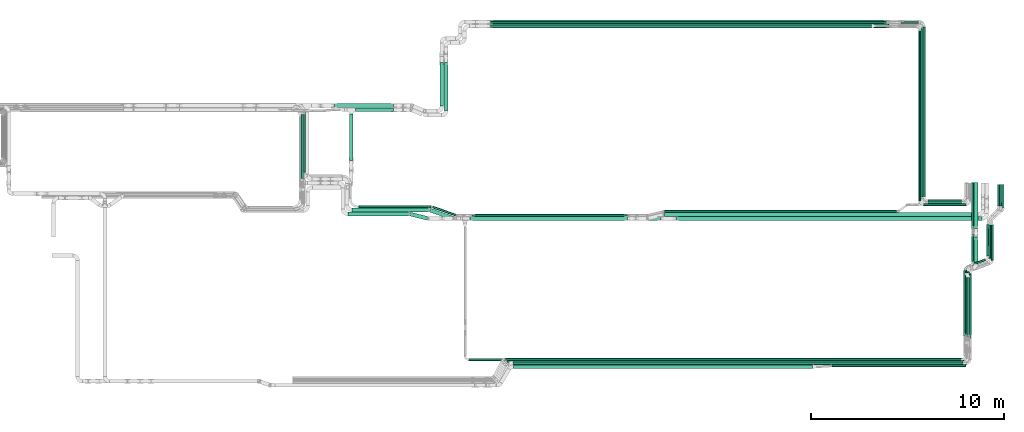
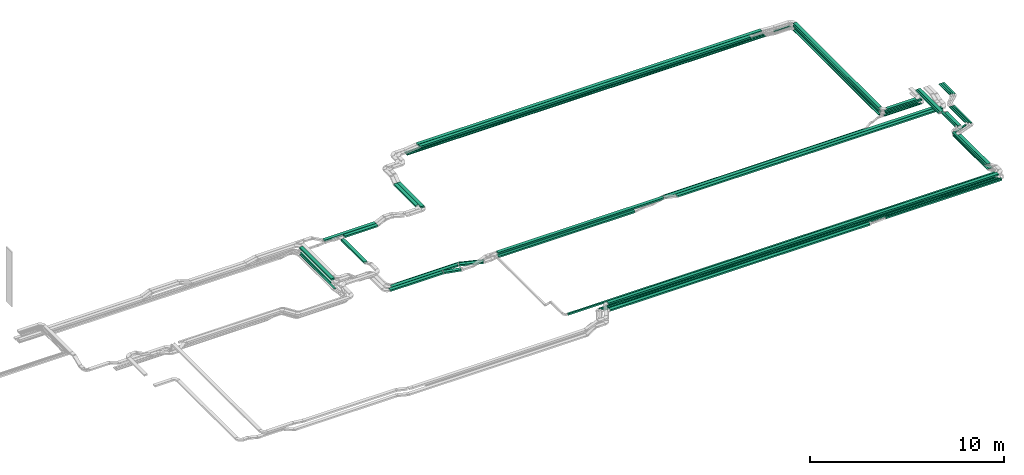
# One storey, part 2 of 25: 59 flow segments.
"""IFC2X3 building model written with IfcOpenShell, lengths in millimetres."""

import ifcopenshell
import ifcopenshell.guid

model = None  # the IFC model being written
_history = None  # IfcOwnerHistory: only IFC2X3 demands one
_inside = {}  # id of a spatial element -> (the spatial element, [elements in it])
_under = {}  # id of a project, library or spatial element -> (it, [spatial elements below it])
_declared = {}  # id of a project -> (the project, [libraries it declares])
_typed = {}  # id of a type object -> (the type object, [elements of that type])
_made_of = {}  # id of a material, layer set ... -> (it, [elements and type objects made of it])


def new_model(schema):
    """Start an empty IFC model of exactly this schema.

    Asked for "IFC4X3", IfcOpenShell would pick the latest addendum, in which some entities
    have other attributes; the version numbers below select the first issue.
    IFC2X3 requires an IfcOwnerHistory on every rooted entity: one is made here for all.
    """
    global model, _history
    if schema == "IFC4X3":
        model = ifcopenshell.file(schema_version=(4, 3, 0, 0))
    else:
        model = ifcopenshell.file(schema=schema)
    _inside.clear()
    _under.clear()
    _declared.clear()
    _typed.clear()
    _made_of.clear()
    _history = None
    if model.schema == "IFC2X3":
        org = make("IfcOrganization", Name="unknown")
        user = make(
            "IfcPersonAndOrganization",
            ThePerson=make("IfcPerson", FamilyName="unknown"),
            TheOrganization=org,
        )
        app = make(
            "IfcApplication",
            ApplicationDeveloper=org,
            Version="unknown",
            ApplicationFullName="unknown",
            ApplicationIdentifier="unknown",
        )
        _history = make(
            "IfcOwnerHistory",
            OwningUser=user,
            OwningApplication=app,
            ChangeAction="ADDED",
            CreationDate=0,
        )
    return model


def make(cls, **values):
    """One entity of the class cls with the attributes given. An attribute that is None is left unset."""
    return model.create_entity(
        cls, **{name: value for name, value in values.items() if value is not None}
    )


def entity(cls, *values):
    """Any entity or typed value of the class cls, its attributes in the order of the schema. None: left unset."""
    e = model.create_entity(cls)
    for i, value in enumerate(values):
        if value is not None:
            e[i] = value
    return e


def rooted(cls, **values):
    """An entity with a GlobalId (a new one), such as an element, a storey or a relation."""
    return make(cls, GlobalId=ifcopenshell.guid.new(), OwnerHistory=_history, **values)


def si_unit(unit_type, name, prefix=None):
    """IfcSIUnit, for example si_unit("LENGTHUNIT", "METRE", prefix="MILLI")."""
    return make("IfcSIUnit", UnitType=unit_type, Prefix=prefix, Name=name)


def converted_unit(unit_type, name, factor, base, dimensions=None, offset=None):
    """IfcConversionBasedUnit, such as the inch: factor (a typed value) times the base unit."""
    return make(
        "IfcConversionBasedUnit"
        if offset is None
        else "IfcConversionBasedUnitWithOffset",
        ConversionOffset=offset,
        Dimensions=None
        if dimensions is None
        else entity("IfcDimensionalExponents", *dimensions),
        UnitType=unit_type,
        Name=name,
        ConversionFactor=make(
            "IfcMeasureWithUnit", ValueComponent=factor, UnitComponent=base
        ),
    )


def derived_unit(unit_type, elements):
    """IfcDerivedUnit: a product of units, each with its exponent."""
    return make(
        "IfcDerivedUnit",
        Elements=[
            make("IfcDerivedUnitElement", Unit=unit, Exponent=power)
            for unit, power in elements
        ],
        UnitType=unit_type,
    )


def assignment(units):
    """IfcUnitAssignment: the units of a project."""
    return None if units is None else make("IfcUnitAssignment", Units=units)


def point(xyz):
    """IfcCartesianPoint."""
    return None if xyz is None else make("IfcCartesianPoint", Coordinates=xyz)


def direction(xyz):
    """IfcDirection."""
    return None if xyz is None else make("IfcDirection", DirectionRatios=xyz)


def frame(location, z_axis=None, x_axis=None):
    """IfcAxis2Placement3D, a coordinate frame: its origin and axes. An axis left out is left unset."""
    return make(
        "IfcAxis2Placement3D",
        Location=point(location),
        Axis=direction(z_axis),
        RefDirection=direction(x_axis),
    )


def frame_2d(location, x_axis=None):
    """IfcAxis2Placement2D, a coordinate frame in the plane: its origin and x axis."""
    return make(
        "IfcAxis2Placement2D", Location=point(location), RefDirection=direction(x_axis)
    )


def origin():
    """The frame at (0, 0, 0) with its axes left unset."""
    return frame((0.0, 0.0, 0.0))


def origin_2d_with_axis():
    """The frame at (0, 0) in the plane with the x axis (1, 0) written out."""
    return frame_2d((0.0, 0.0), x_axis=(1.0, 0.0))


def place(relative_to, where):
    """IfcLocalPlacement: puts the frame where relative to a parent placement (None: the world)."""
    return make(
        "IfcLocalPlacement", PlacementRelTo=relative_to, RelativePlacement=where
    )


def context(
    kind, dimensions, precision=None, world=None, true_north=None, identifier=None
):
    """IfcGeometricRepresentationContext, for example the 3D "Model" context."""
    return make(
        "IfcGeometricRepresentationContext",
        ContextIdentifier=identifier,
        ContextType=kind,
        CoordinateSpaceDimension=dimensions,
        Precision=precision,
        WorldCoordinateSystem=world,
        TrueNorth=true_north,
    )


def subcontext(parent, identifier, kind, view, scale=None):
    """IfcGeometricRepresentationSubContext, for example "Body" below "Model"."""
    return make(
        "IfcGeometricRepresentationSubContext",
        ContextIdentifier=identifier,
        ContextType=kind,
        ParentContext=parent,
        TargetScale=scale,
        TargetView=view,
    )


def project(units=None, contexts=None):
    """IfcProject with its units and contexts."""
    return rooted(
        "IfcProject",
        Name="project",
        RepresentationContexts=contexts,
        UnitsInContext=assignment(units),
    )


def spatial(cls, under=None, at=None, **own):
    """A site, building, storey or space (cls), placed at a placement, below another one or the project."""
    s = rooted(cls, ObjectPlacement=at, **own)
    if under is not None:
        _under.setdefault(under.id(), (under, []))[1].append(s)
    return s


def profile(cls, at=None, kind="AREA", **sizes):
    """A parametric profile (cls). Its sizes go by their IFC names, for example OverallWidth=200.0."""
    return make(cls, ProfileType=kind, Position=at, **sizes)


def rectangle(**sizes):
    """IfcRectangleProfileDef."""
    return profile("IfcRectangleProfileDef", **sizes)


def extrude(swept, where, along, depth):
    """IfcExtrudedAreaSolid: the profile swept, set in the frame where, extruded along a direction by depth."""
    return make(
        "IfcExtrudedAreaSolid",
        SweptArea=swept,
        Position=where,
        ExtrudedDirection=direction(along),
        Depth=depth,
    )


def shape(context_of_items, identifier, shape_type, items):
    """IfcShapeRepresentation: the items that make up one representation, for example the "Body"."""
    return make(
        "IfcShapeRepresentation",
        ContextOfItems=context_of_items,
        RepresentationIdentifier=identifier,
        RepresentationType=shape_type,
        Items=items,
    )


def made_of(thing, what):
    """Note that an element or type object is made of a material, layer set ...; save() writes the relation."""
    if what is not None:
        _made_of.setdefault(what.id(), (what, []))[1].append(thing)
    return thing


def type_object(cls, material=None, **own):
    """A type object (cls), such as IfcWallType, which elements share."""
    return made_of(rooted(cls, **own), material)


def element(
    cls,
    number,
    at=None,
    inside=None,
    cuts=None,
    type_object=None,
    material=None,
    context=None,
    identifier="Body",
    shape_type=None,
    held_by="IfcProductDefinitionShape",
    body=None,
    shapes=None,
    **own,
):
    """One element of the class cls, such as IfcWall. Its Tag is "e" and its number.

    at: its placement. inside: the storey or other place that contains it. cuts: it is an
    opening in that element (IfcRelVoidsElement). A single representation is given by context,
    identifier, shape_type and body (its items); several are given by shapes. held_by: the class
    of the entity that holds the representations. save() writes the other relations.
    """
    e = rooted(cls, Tag="e%d" % number, ObjectPlacement=at, **own)
    if body is not None:
        shapes = [shape(context, identifier, shape_type, body)]
    if shapes is not None:
        e.Representation = make(held_by, Representations=shapes)
    if inside is not None:
        _inside.setdefault(inside.id(), (inside, []))[1].append(e)
    if cuts is not None:
        rooted(
            "IfcRelVoidsElement", RelatingBuildingElement=cuts, RelatedOpeningElement=e
        )
    if type_object is not None:
        _typed.setdefault(type_object.id(), (type_object, []))[1].append(e)
    return made_of(e, material)


def aggregate(whole, parts):
    """IfcRelAggregates: a whole, such as a stair, and the parts it consists of."""
    return rooted("IfcRelAggregates", RelatingObject=whole, RelatedObjects=parts)


def save(model, path):
    """Write the relations noted so far, then the file.

    IfcRelAggregates (storeys below a building ...), IfcRelContainedInSpatialStructure (elements
    in a storey), IfcRelDefinesByType, IfcRelAssociatesMaterial and IfcRelDeclares: one each for
    every whole, place, type object, material and project.
    """
    for whole, parts in _under.values():
        aggregate(whole, parts)
    for where, things in _inside.values():
        rooted(
            "IfcRelContainedInSpatialStructure",
            RelatedElements=things,
            RelatingStructure=where,
        )
    for kind, things in _typed.values():
        rooted("IfcRelDefinesByType", RelatedObjects=things, RelatingType=kind)
    for what, things in _made_of.values():
        rooted("IfcRelAssociatesMaterial", RelatedObjects=things, RelatingMaterial=what)
    for by, libraries in _declared.values():
        rooted("IfcRelDeclares", RelatingContext=by, RelatedDefinitions=libraries)
    model.write(path)


model = new_model("IFC2X3")

# Units and contexts
model_context = context("Model", 3, precision=0.01, world=origin(), true_north=direction((6.12303176911189e-17, 1.0)))
body_context = subcontext(model_context, "Body", "Model", "MODEL_VIEW")
ifc_project = project(units=[si_unit("LENGTHUNIT", "METRE", prefix="MILLI"), si_unit("AREAUNIT", "SQUARE_METRE"), si_unit("VOLUMEUNIT", "CUBIC_METRE"), converted_unit("PLANEANGLEUNIT", "DEGREE", entity("IfcRatioMeasure", 0.0174532925199433), si_unit("PLANEANGLEUNIT", "RADIAN"), dimensions=[0, 0, 0, 0, 0, 0, 0]), si_unit("MASSUNIT", "GRAM", prefix="KILO"), derived_unit("MASSDENSITYUNIT", [(si_unit("MASSUNIT", "GRAM", prefix="KILO"), 1), (si_unit("LENGTHUNIT", "METRE"), -3)]), derived_unit("MOMENTOFINERTIAUNIT", [(si_unit("LENGTHUNIT", "METRE"), 4)]), si_unit("TIMEUNIT", "SECOND"), si_unit("FREQUENCYUNIT", "HERTZ"), si_unit("THERMODYNAMICTEMPERATUREUNIT", "DEGREE_CELSIUS"), derived_unit("THERMALTRANSMITTANCEUNIT", [(si_unit("MASSUNIT", "GRAM", prefix="KILO"), 1), (si_unit("THERMODYNAMICTEMPERATUREUNIT", "KELVIN"), -1), (si_unit("TIMEUNIT", "SECOND"), -3)]), derived_unit("VOLUMETRICFLOWRATEUNIT", [(si_unit("LENGTHUNIT", "METRE"), 3), (si_unit("TIMEUNIT", "SECOND"), -1)]), derived_unit("MASSFLOWRATEUNIT", [(si_unit("MASSUNIT", "GRAM", prefix="KILO"), 1), (si_unit("TIMEUNIT", "SECOND"), -1)]), derived_unit("ROTATIONALFREQUENCYUNIT", [(si_unit("TIMEUNIT", "SECOND"), -1)]), si_unit("ELECTRICCURRENTUNIT", "AMPERE"), si_unit("ELECTRICVOLTAGEUNIT", "VOLT"), si_unit("POWERUNIT", "WATT"), si_unit("FORCEUNIT", "NEWTON", prefix="KILO"), si_unit("ILLUMINANCEUNIT", "LUX"), si_unit("LUMINOUSFLUXUNIT", "LUMEN"), si_unit("LUMINOUSINTENSITYUNIT", "CANDELA"), derived_unit("USERDEFINED", [(si_unit("MASSUNIT", "GRAM", prefix="KILO"), -1), (si_unit("LENGTHUNIT", "METRE"), -2), (si_unit("TIMEUNIT", "SECOND"), 3), (si_unit("LUMINOUSFLUXUNIT", "LUMEN"), 1)]), derived_unit("LINEARVELOCITYUNIT", [(si_unit("LENGTHUNIT", "METRE"), 1), (si_unit("TIMEUNIT", "SECOND"), -1)]), si_unit("PRESSUREUNIT", "PASCAL"), derived_unit("USERDEFINED", [(si_unit("LENGTHUNIT", "METRE"), -2), (si_unit("MASSUNIT", "GRAM", prefix="KILO"), 1), (si_unit("TIMEUNIT", "SECOND"), -2)]), derived_unit("LINEARFORCEUNIT", [(si_unit("MASSUNIT", "GRAM", prefix="KILO"), 1), (si_unit("LENGTHUNIT", "METRE"), 1), (si_unit("TIMEUNIT", "SECOND"), -2), (si_unit("LENGTHUNIT", "METRE"), -1)]), derived_unit("PLANARFORCEUNIT", [(si_unit("MASSUNIT", "GRAM", prefix="KILO"), 1), (si_unit("LENGTHUNIT", "METRE"), 1), (si_unit("TIMEUNIT", "SECOND"), -2), (si_unit("LENGTHUNIT", "METRE"), -2)])], contexts=[model_context])

# Site, building, storey
site_placement = place(None, frame((0.0, -0.00077364408347762, 0.0)))
site = spatial("IfcSite", under=ifc_project, at=site_placement, CompositionType="ELEMENT")
building_placement = place(site_placement, origin())
building = spatial("IfcBuilding", under=site, at=building_placement, CompositionType="ELEMENT")
storey_placement = place(building_placement, frame((0.0, 0.0, 24000.0)))
storey = spatial("IfcBuildingStorey", under=building, at=storey_placement, CompositionType="ELEMENT", Elevation=24000.0)

# Flow segments
cable_carrier_segment_type = type_object("IfcCableCarrierSegmentType", PredefinedType="CABLETRAYSEGMENT")
flow_segment_1_placement = place(storey_placement, frame((35765.6156945545, 14367.8235638229, 2650.0)))
element("IfcFlowSegment", 1, at=flow_segment_1_placement, inside=storey, type_object=cable_carrier_segment_type, context=body_context, shape_type="SweptSolid", body=[
    extrude(rectangle(XDim=1961.74448976482, YDim=199.999999999998, at=frame_2d((-2.1600499167107e-12, 0.0), x_axis=(1.0, 0.0))), frame((980.872244882413, 100.0, 0.0)), (0.0, 0.0, 1.0), 100.000000000003),
])
flow_segment_2_placement = place(storey_placement, frame((35435.6156945545, 11850.480257693, 2650.0)))
element("IfcFlowSegment", 2, at=flow_segment_2_placement, inside=storey, type_object=cable_carrier_segment_type, context=body_context, shape_type="SweptSolid", body=[
    extrude(rectangle(XDim=2387.34330612991, YDim=199.999999999998, at=frame_2d((-1.02318153949454e-12, 0.0), x_axis=(1.0, 0.0))), frame((100.0, 1193.67165306495, 0.0), z_axis=(0.0, 0.0, 1.0), x_axis=(0.0, -1.0, 0.0)), (0.0, 0.0, 1.0), 100.000000000003),
])
flow_segment_3_placement = place(storey_placement, frame((34655.686744187, 14577.8235638228, 2650.0)))
element("IfcFlowSegment", 3, at=flow_segment_3_placement, inside=storey, type_object=cable_carrier_segment_type, context=body_context, shape_type="SweptSolid", body=[
    extrude(rectangle(XDim=3071.67344013226, YDim=199.999999999998, at=frame_2d((-2.1600499167107e-12, -1.08002495835535e-12), x_axis=(1.0, 0.0))), frame((1535.83672006613, 100.0, 0.0), z_axis=(0.0, 0.0, 1.0), x_axis=(-1.0, 0.0, 0.0)), (0.0, 0.0, 1.0), 99.9999999999989),
])
flow_segment_4_placement = place(storey_placement, frame((65130.0810452562, 9971.0, 2972.82677247422)))
element("IfcFlowSegment", 4, at=flow_segment_4_placement, inside=storey, type_object=cable_carrier_segment_type, context=body_context, shape_type="SweptSolid", body=[
    extrude(rectangle(XDim=8798.00000000002, YDim=99.9999999999946, at=frame_2d((9.09494701772928e-13, 4.33075797445781e-12), x_axis=(1.0, 0.0))), frame((50.0, 4399.0, 0.0), z_axis=(0.0, 0.0, 1.0), x_axis=(0.0, -1.0, 0.0)), (0.0, 0.0, 1.0), 49.9999999999973),
])
flow_segment_5_placement = place(storey_placement, frame((65020.0810452562, 9861.0, 2972.82677247422)))
element("IfcFlowSegment", 5, at=flow_segment_5_placement, inside=storey, type_object=cable_carrier_segment_type, context=body_context, shape_type="SweptSolid", body=[
    extrude(rectangle(XDim=8798.00000000002, YDim=99.9999999999946, at=frame_2d((0.0, -4.33075797445781e-12), x_axis=(1.0, 0.0))), frame((50.0, 4399.0, 0.0), z_axis=(0.0, 0.0, 1.0), x_axis=(0.0, -1.0, 0.0)), (0.0, 0.0, 1.0), 49.9999999999973),
])
flow_segment_6_placement = place(storey_placement, frame((43924.8800132922, 1069.69184714198, 3217.23038971969)))
element("IfcFlowSegment", 6, at=flow_segment_6_placement, inside=storey, type_object=cable_carrier_segment_type, context=body_context, shape_type="SweptSolid", body=[
    extrude(rectangle(XDim=15479.0908343116, YDim=200.0, at=origin_2d_with_axis()), frame((7739.54541715578, 100.0, 0.0), z_axis=(0.0, 0.0, 1.0), x_axis=(-1.0, 0.0, 0.0)), (0.0, 0.0, 1.0), 100.000000000003),
])
flow_segment_7_placement = place(storey_placement, frame((51733.9010513302, 9154.98923132572, 2805.0)))
element("IfcFlowSegment", 7, at=flow_segment_7_placement, inside=storey, type_object=cable_carrier_segment_type, context=body_context, shape_type="SweptSolid", body=[
    extrude(rectangle(XDim=12038.4671980296, YDim=99.9999999999989, at=frame_2d((4.54747350886464e-12, 1.08357767203415e-12), x_axis=(1.0, 0.0))), frame((6019.23359901477, 50.0, 0.0)), (0.0, 0.0, 1.0), 49.9999999999973),
])
flow_segment_8_placement = place(storey_placement, frame((52335.6191942921, 8734.98923132584, 2805.0)))
element("IfcFlowSegment", 8, at=flow_segment_8_placement, inside=storey, type_object=cable_carrier_segment_type, context=body_context, shape_type="SweptSolid", body=[
    extrude(rectangle(XDim=15832.6193035877, YDim=200.0, at=frame_2d((-4.54747350886464e-12, 0.0), x_axis=(1.0, 0.0))), frame((7916.30965179384, 100.0, 0.0)), (0.0, 0.0, 1.0), 100.000000000003),
])
flow_segment_9_placement = place(storey_placement, frame((42732.4035607541, 18910.0, 3245.40293241792)))
element("IfcFlowSegment", 9, at=flow_segment_9_placement, inside=storey, type_object=cable_carrier_segment_type, context=body_context, shape_type="SweptSolid", body=[
    extrude(rectangle(XDim=20513.0370032506, YDim=200.000000000002, at=frame_2d((0.0, 1.08713038571295e-12), x_axis=(1.0, 0.0))), frame((10256.5185016253, 100.0, 0.0)), (0.0, 0.0, 1.0), 100.000000000003),
])
flow_segment_10_placement = place(storey_placement, frame((42732.375867914, 18700.0, 3245.40293241791)))
element("IfcFlowSegment", 10, at=flow_segment_10_placement, inside=storey, type_object=cable_carrier_segment_type, context=body_context, shape_type="SweptSolid", body=[
    extrude(rectangle(XDim=19736.1029536707, YDim=199.999999999998, at=frame_2d((0.0, -1.08002495835535e-12), x_axis=(1.0, 0.0))), frame((9868.05147683536, 100.0, 0.0)), (0.0, 0.0, 1.0), 100.000000000003),
])
flow_segment_11_placement = place(storey_placement, frame((41967.5258156246, 18700.0, 3045.40293241791)))
element("IfcFlowSegment", 11, at=flow_segment_11_placement, inside=storey, type_object=cable_carrier_segment_type, context=body_context, shape_type="SweptSolid", body=[
    extrude(rectangle(XDim=21395.2924590022, YDim=99.9999999999989, at=frame_2d((0.0, 1.08357767203415e-12), x_axis=(1.0, 0.0))), frame((10697.6462295011, 50.0, 0.0)), (0.0, 0.0, 1.0), 49.9999999999973),
])
flow_segment_12_placement = place(storey_placement, frame((41968.4788215846, 18810.0, 3045.40293241791)))
element("IfcFlowSegment", 12, at=flow_segment_12_placement, inside=storey, type_object=cable_carrier_segment_type, context=body_context, shape_type="SweptSolid", body=[
    extrude(rectangle(XDim=21395.2882878374, YDim=99.9999999999989, at=frame_2d((0.0, -1.08357767203415e-12), x_axis=(1.0, 0.0))), frame((10697.6441439187, 50.0, 0.0)), (0.0, 0.0, 1.0), 49.9999999999973),
])
flow_segment_13_placement = place(storey_placement, frame((41967.5258156246, 18920.0, 3045.40293241791)))
element("IfcFlowSegment", 13, at=flow_segment_13_placement, inside=storey, type_object=cable_carrier_segment_type, context=body_context, shape_type="SweptSolid", body=[
    extrude(rectangle(XDim=21395.2924590022, YDim=99.9999999999989, at=frame_2d((4.54747350886464e-12, -1.08357767203415e-12), x_axis=(1.0, 0.0))), frame((10697.6462295011, 50.0, 0.0)), (0.0, 0.0, 1.0), 49.9999999999973),
])
flow_segment_14_placement = place(storey_placement, frame((41771.8425432936, 8949.9892507805, 2720.0)))
element("IfcFlowSegment", 14, at=flow_segment_14_placement, inside=storey, type_object=cable_carrier_segment_type, context=body_context, shape_type="SweptSolid", body=[
    extrude(rectangle(XDim=8053.84090120549, YDim=99.9999999999989, at=frame_2d((0.0, 5.40012479177676e-13), x_axis=(1.0, 0.0))), frame((4026.92045060275, 50.0, 0.0), z_axis=(0.0, 0.0, 1.0), x_axis=(-1.0, 0.0, 0.0)), (0.0, 0.0, 1.0), 49.9999999999973),
])
flow_segment_15_placement = place(storey_placement, frame((41674.2528539682, 8739.98925078063, 2720.0)))
element("IfcFlowSegment", 15, at=flow_segment_15_placement, inside=storey, type_object=cable_carrier_segment_type, context=body_context, shape_type="SweptSolid", body=[
    extrude(rectangle(XDim=8148.49829971334, YDim=200.0, at=frame_2d((-4.32009983342141e-12, 0.0), x_axis=(1.0, 0.0))), frame((4074.24914985668, 100.0, 0.0), z_axis=(0.0, 0.0, 1.0), x_axis=(-1.0, 0.0, 0.0)), (0.0, 0.0, 1.0), 100.000000000003),
])
flow_segment_16_placement = place(storey_placement, frame((51739.883773986, 8944.98923132585, 2805.0)))
element("IfcFlowSegment", 16, at=flow_segment_16_placement, inside=storey, type_object=cable_carrier_segment_type, context=body_context, shape_type="SweptSolid", body=[
    extrude(rectangle(XDim=16237.8207927538, YDim=200.0, at=origin_2d_with_axis()), frame((8118.91039637691, 100.0, 0.0)), (0.0, 0.0, 1.0), 100.000000000003),
])
flow_segment_17_placement = place(storey_placement, frame((40330.6005282686, 14420.3144759065, 2883.62105725888)))
element("IfcFlowSegment", 17, at=flow_segment_17_placement, inside=storey, type_object=cable_carrier_segment_type, context=body_context, shape_type="SweptSolid", body=[
    extrude(rectangle(XDim=2490.37832088763, YDim=200.000000000007, at=frame_2d((-1.13686837721616e-12, 0.0), x_axis=(1.0, 0.0))), frame((100.0, 1245.18916044382, 0.0), z_axis=(0.0, 0.0, 1.0), x_axis=(0.0, -1.0, 0.0)), (0.0, 0.0, 1.0), 100.000000000008),
])
flow_segment_18_placement = place(storey_placement, frame((40120.6005282686, 14651.3144759065, 2883.62105725889)))
element("IfcFlowSegment", 18, at=flow_segment_18_placement, inside=storey, type_object=cable_carrier_segment_type, context=body_context, shape_type="SweptSolid", body=[
    extrude(rectangle(XDim=2256.12450469831, YDim=200.000000000007, at=frame_2d((-1.13686837721616e-12, 0.0), x_axis=(1.0, 0.0))), frame((100.0, 1128.06225234915, 0.0), z_axis=(0.0, 0.0, 1.0), x_axis=(0.0, -1.0, 0.0)), (0.0, 0.0, 1.0), 100.000000000003),
])
flow_segment_19_placement = place(storey_placement, frame((32943.0827924389, 10611.4765215059, 2650.0)))
element("IfcFlowSegment", 19, at=flow_segment_19_placement, inside=storey, type_object=cable_carrier_segment_type, context=body_context, shape_type="SweptSolid", body=[
    extrude(rectangle(XDim=3596.34704231681, YDim=100.000000000003, at=frame_2d((-1.13686837721616e-12, -2.16715534406831e-12), x_axis=(1.0, 0.0))), frame((50.0, 1798.17352115841, 0.0), z_axis=(0.0, 0.0, 1.0), x_axis=(0.0, -1.0, 0.0)), (0.0, 0.0, 1.0), 49.9999999999973),
])
flow_segment_20_placement = place(storey_placement, frame((32943.0827924389, 10906.9003960973, 3040.0)))
element("IfcFlowSegment", 20, at=flow_segment_20_placement, inside=storey, type_object=cable_carrier_segment_type, context=body_context, shape_type="SweptSolid", body=[
    extrude(rectangle(XDim=3309.92316772554, YDim=199.999999999998, at=frame_2d((1.13686837721616e-12, 0.0), x_axis=(1.0, 0.0))), frame((100.0, 1654.96158386277, 0.0), z_axis=(0.0, 0.0, 1.0), x_axis=(0.0, -1.0, 0.0)), (0.0, 0.0, 1.0), 100.000000000003),
])
flow_segment_21_placement = place(storey_placement, frame((35364.0827924388, 8974.94253623849, 2660.0)))
element("IfcFlowSegment", 21, at=flow_segment_21_placement, inside=storey, type_object=cable_carrier_segment_type, context=body_context, shape_type="SweptSolid", body=[
    extrude(rectangle(XDim=3156.52524029667, YDim=200.0, at=frame_2d((0.0, -5.47117906535277e-13), x_axis=(1.0, 0.0))), frame((1578.26262014834, 100.0, 0.0)), (0.0, 0.0, 1.0), 100.000000000003),
])
flow_segment_22_placement = place(storey_placement, frame((35574.0827924389, 9184.9425362385, 2660.0)))
element("IfcFlowSegment", 22, at=flow_segment_22_placement, inside=storey, type_object=cable_carrier_segment_type, context=body_context, shape_type="SweptSolid", body=[
    extrude(rectangle(XDim=3953.5852497596, YDim=200.0, at=frame_2d((-2.1600499167107e-12, 0.0), x_axis=(1.0, 0.0))), frame((1976.79262487981, 100.0, 0.0)), (0.0, 0.0, 1.0), 100.000000000003),
])
flow_segment_23_placement = place(storey_placement, frame((33053.0827924433, 11226.9000648387, 2650.0)))
element("IfcFlowSegment", 23, at=flow_segment_23_placement, inside=storey, type_object=cable_carrier_segment_type, context=body_context, shape_type="SweptSolid", body=[
    extrude(rectangle(XDim=3090.92316799697, YDim=99.999999991219, at=frame_2d((0.0, -2.16360263038951e-12), x_axis=(1.0, 0.0))), frame((50.0, 1545.46158386282, 0.0204778842241808), z_axis=(0.0, 1.32503353277792e-05, 1.0), x_axis=(0.0, -1.0, 1.32503353277792e-05)), (0.0, 0.0, 1.0), 49.999999995611),
])
flow_segment_24_placement = place(storey_placement, frame((35923.0827924389, 9394.94253623869, 2660.0)))
element("IfcFlowSegment", 24, at=flow_segment_24_placement, inside=storey, type_object=cable_carrier_segment_type, context=body_context, shape_type="SweptSolid", body=[
    extrude(rectangle(XDim=3743.01383141403, YDim=100.000000000001, at=frame_2d((2.1600499167107e-12, -5.43565192856477e-13), x_axis=(1.0, 0.0))), frame((1871.50691570702, 50.0, 0.0)), (0.0, 0.0, 1.0), 49.9999999999973),
])
flow_segment_25_placement = place(storey_placement, frame((38558.9260124352, 8745.66269005957, 2660.0)))
element("IfcFlowSegment", 25, at=flow_segment_25_placement, inside=storey, type_object=cable_carrier_segment_type, context=body_context, shape_type="SweptSolid", body=[
    extrude(rectangle(XDim=926.743066728364, YDim=199.999999999995, at=frame_2d((-2.8421709430404e-13, 1.05160324892495e-12), x_axis=(1.0, 0.0))), frame((473.793407468182, 209.303193722955, 0.0), z_axis=(0.0, 0.0, 1.0), x_axis=(-0.970196742340564, 0.242318553048991, 0.0)), (0.0, 0.0, 1.0), 100.000000000003),
])
flow_segment_26_placement = place(storey_placement, frame((39578.7869179355, 8759.65892951443, 2660.0)))
element("IfcFlowSegment", 26, at=flow_segment_26_placement, inside=storey, type_object=cable_carrier_segment_type, context=body_context, shape_type="SweptSolid", body=[
    extrude(rectangle(XDim=1270.99252740195, YDim=200.000000000001, at=frame_2d((4.03588273911737e-12, 1.4210854715202e-12), x_axis=(1.0, 0.0))), frame((633.15995351925, 302.806963995782, 0.0), z_axis=(0.0, 0.0, 1.0), x_axis=(-0.944737568154261, 0.327827587792688, 0.0)), (0.0, 0.0, 1.0), 100.000000000003),
])
flow_segment_27_placement = place(storey_placement, frame((39717.21549959, 8964.13268632976, 2660.0)))
element("IfcFlowSegment", 27, at=flow_segment_27_placement, inside=storey, type_object=cable_carrier_segment_type, context=body_context, shape_type="SweptSolid", body=[
    extrude(rectangle(XDim=1287.8496907078, YDim=100.000000000007, at=frame_2d((-4.2632564145606e-12, -8.95283847057726e-13), x_axis=(1.0, 0.0))), frame((624.731371863382, 258.333207179871, 0.0), z_axis=(0.0, 0.0, 1.0), x_axis=(-0.944737568154257, 0.327827587792702, 0.0)), (0.0, 0.0, 1.0), 49.9999999999929),
])
flow_segment_28_placement = place(storey_placement, frame((41655.1084711671, 8734.98923132583, 2970.0)))
element("IfcFlowSegment", 28, at=flow_segment_28_placement, inside=storey, type_object=cable_carrier_segment_type, context=body_context, shape_type="SweptSolid", body=[
    extrude(rectangle(XDim=9887.21265595425, YDim=200.0, at=frame_2d((-4.54747350886464e-12, -5.47117906535277e-13), x_axis=(1.0, 0.0))), frame((4943.60632797712, 100.0, 0.0), z_axis=(0.0, 0.0, 1.0), x_axis=(-1.0, 0.0, 0.0)), (0.0, 0.0, 1.0), 100.000000000003),
])
flow_segment_29_placement = place(storey_placement, frame((63984.7885862542, 18920.0, 2972.8267724742)))
element("IfcFlowSegment", 29, at=flow_segment_29_placement, inside=storey, type_object=cable_carrier_segment_type, context=body_context, shape_type="SweptSolid", body=[
    extrude(rectangle(XDim=994.292459002089, YDim=99.9999999999989, at=frame_2d((-4.34852154285181e-12, -1.08357767203415e-12), x_axis=(1.0, 0.0))), frame((497.146229501049, 50.0, 0.0), z_axis=(0.0, 0.0, 1.0), x_axis=(-1.0, 0.0, 0.0)), (0.0, 0.0, 1.0), 49.9999999999973),
])
flow_segment_30_placement = place(storey_placement, frame((65381.0810452562, 9720.0, 2972.82677247422)))
element("IfcFlowSegment", 30, at=flow_segment_30_placement, inside=storey, type_object=cable_carrier_segment_type, context=body_context, shape_type="SweptSolid", body=[
    extrude(rectangle(XDim=1753.44655483797, YDim=99.9999999999989, at=frame_2d((4.32009983342141e-12, 0.0), x_axis=(1.0, 0.0))), frame((876.723277418989, 50.0, 0.0)), (0.0, 0.0, 1.0), 49.9999999999973),
])
flow_segment_31_placement = place(storey_placement, frame((65271.0810452562, 9610.0, 2972.82677247422)))
element("IfcFlowSegment", 31, at=flow_segment_31_placement, inside=storey, type_object=cable_carrier_segment_type, context=body_context, shape_type="SweptSolid", body=[
    extrude(rectangle(XDim=1973.44655483796, YDim=99.9999999999989, at=origin_2d_with_axis()), frame((986.723277418982, 50.0, 0.0)), (0.0, 0.0, 1.0), 49.9999999999973),
])
flow_segment_32_placement = place(storey_placement, frame((64910.0810452562, 9730.0, 2972.82677247422)))
element("IfcFlowSegment", 32, at=flow_segment_32_placement, inside=storey, type_object=cable_carrier_segment_type, context=body_context, shape_type="SweptSolid", body=[
    extrude(rectangle(XDim=8819.00000000003, YDim=99.9999999999946, at=frame_2d((9.09494701772928e-13, -4.33075797445781e-12), x_axis=(1.0, 0.0))), frame((50.0, 4409.50000000001, 0.0), z_axis=(0.0, 0.0, 1.0), x_axis=(0.0, -1.0, 0.0)), (0.0, 0.0, 1.0), 49.9999999999973),
])
flow_segment_33_placement = place(storey_placement, frame((65030.0810452562, 9961.0, 3187.82677247422)))
element("IfcFlowSegment", 33, at=flow_segment_33_placement, inside=storey, type_object=cable_carrier_segment_type, context=body_context, shape_type="SweptSolid", body=[
    extrude(rectangle(XDim=8798.00000000003, YDim=200.000000000007, at=origin_2d_with_axis()), frame((100.0, 4399.0, 0.0), z_axis=(0.0, 0.0, 1.0), x_axis=(0.0, -1.0, 0.0)), (0.0, 0.0, 1.0), 100.000000000003),
])
flow_segment_34_placement = place(storey_placement, frame((65381.0810452562, 9610.0, 3187.82677247422)))
element("IfcFlowSegment", 34, at=flow_segment_34_placement, inside=storey, type_object=cable_carrier_segment_type, context=body_context, shape_type="SweptSolid", body=[
    extrude(rectangle(XDim=1738.00000000001, YDim=200.0, at=frame_2d((-4.32009983342141e-12, -5.47117906535277e-13), x_axis=(1.0, 0.0))), frame((869.0, 100.0, 0.0), z_axis=(0.0, 0.0, 1.0), x_axis=(-1.0, 0.0, 0.0)), (0.0, 0.0, 1.0), 100.000000000003),
])
flow_segment_35_placement = place(storey_placement, frame((65140.0810452562, 9500.0, 2972.82677247422)))
element("IfcFlowSegment", 35, at=flow_segment_35_placement, inside=storey, type_object=cable_carrier_segment_type, context=body_context, shape_type="SweptSolid", body=[
    extrude(rectangle(XDim=2214.44655483797, YDim=99.9999999999989, at=frame_2d((4.32009983342141e-12, 5.40012479177676e-13), x_axis=(1.0, 0.0))), frame((1107.22327741898, 50.0, 0.0), z_axis=(0.0, 0.0, 1.0), x_axis=(-1.0, 0.0, 0.0)), (0.0, 0.0, 1.0), 49.9999999999973),
])
flow_segment_36_placement = place(storey_placement, frame((64920.0810452562, 9751.0, 3187.82677247422)))
element("IfcFlowSegment", 36, at=flow_segment_36_placement, inside=storey, type_object=cable_carrier_segment_type, context=body_context, shape_type="SweptSolid", body=[
    extrude(rectangle(XDim=8848.00000000016, YDim=99.9999999999946, at=frame_2d((4.54747350886464e-13, -4.33075797445781e-12), x_axis=(1.0, 0.0))), frame((50.0, 4424.0, 0.0), z_axis=(0.0, 0.0, 1.0), x_axis=(0.0, -1.0, 0.0)), (0.0, 0.0, 1.0), 100.000000000003),
])
flow_segment_37_placement = place(storey_placement, frame((65171.0810452562, 9500.0, 3187.82677247422)))
element("IfcFlowSegment", 37, at=flow_segment_37_placement, inside=storey, type_object=cable_carrier_segment_type, context=body_context, shape_type="SweptSolid", body=[
    extrude(rectangle(XDim=2183.44655483798, YDim=99.9999999999989, at=frame_2d((-4.32009983342141e-12, -1.08357767203415e-12), x_axis=(1.0, 0.0))), frame((1091.723277419, 50.0, 0.0)), (0.0, 0.0, 1.0), 100.000000000003),
])
flow_segment_38_placement = place(storey_placement, frame((67766.3475285465, 8313.7460894415, 2955.26809891815)))
element("IfcFlowSegment", 38, at=flow_segment_38_placement, inside=storey, type_object=cable_carrier_segment_type, context=body_context, shape_type="SweptSolid", body=[
    extrude(rectangle(XDim=2386.77265957814, YDim=200.000000000007, at=origin_2d_with_axis()), frame((100.0, 1193.38632978907, 0.0), z_axis=(0.0, 0.0, 1.0), x_axis=(0.0, 1.0, 0.0)), (0.0, 0.0, 1.0), 100.000000000003),
])
flow_segment_39_placement = place(storey_placement, frame((68996.3150685969, 9477.22387420897, 2970.07829621774)))
element("IfcFlowSegment", 39, at=flow_segment_39_placement, inside=storey, type_object=cable_carrier_segment_type, context=body_context, shape_type="SweptSolid", body=[
    extrude(rectangle(XDim=49.9999999999984, YDim=1113.08678124436, at=frame_2d((1.08002495835535e-12, 2.16893170090771e-12), x_axis=(0.0, 1.0))), frame((0.000715960507341151, 556.663497640899, 27.830923651134), z_axis=(1.0, -1.28642484897292e-06, 6.54438427708494e-09), x_axis=(1.28644149537419e-06, 0.999987060117084, -0.00508719930179811)), (0.0, 0.0, 1.0), 100.000000000017),
])
flow_segment_40_placement = place(storey_placement, frame((69106.315146688, 9459.66377822632, 2970.07827860637)))
element("IfcFlowSegment", 40, at=flow_segment_40_placement, inside=storey, type_object=cable_carrier_segment_type, context=body_context, shape_type="SweptSolid", body=[
    extrude(rectangle(XDim=50.0000000000039, YDim=1130.64982762595, at=frame_2d((0.0, 0.0), x_axis=(0.0, 1.0))), frame((0.000676915004169132, 565.44178066379, 27.7960942497904), z_axis=(1.0, -1.19737642217187e-06, 5.92293818108424e-09), x_axis=(1.1973910712753e-06, 0.999987765814664, -0.00494653611768659)), (0.0, 0.0, 1.0), 99.9999999999969),
])
flow_segment_41_placement = place(storey_placement, frame((69216.3165005179, 9406.28264063293, 2970.0782643162)))
element("IfcFlowSegment", 41, at=flow_segment_41_placement, inside=storey, type_object=cable_carrier_segment_type, context=body_context, shape_type="SweptSolid", body=[
    extrude(rectangle(XDim=50.0000000000024, YDim=1184.03397215071, at=frame_2d((5.6843418860808e-13, 3.5527136788005e-15), x_axis=(0.0, 1.0))), frame((0.0, 592.130767267439, 27.8574605259114), z_axis=(1.0, 0.0, 0.0), x_axis=(0.0, 0.999988349268031, -0.00482714493236797)), (0.0, 0.0, 1.0), 100.000000000003),
])
flow_segment_42_placement = place(storey_placement, frame((67460.790212426, 6325.18289477948, 2990.04864206768)))
element("IfcFlowSegment", 42, at=flow_segment_42_placement, inside=storey, type_object=cable_carrier_segment_type, context=body_context, shape_type="SweptSolid", body=[
    extrude(rectangle(XDim=936.699448046719, YDim=99.999999950971, at=frame_2d((4.06430444854777e-12, -1.54898316395702e-12), x_axis=(1.0, 0.0))), frame((455.132160659936, 214.618692294763, 0.0146655023701783), z_axis=(2.92307110406685e-05, 1.12284692556801e-05, 1.0), x_axis=(-0.933496521062262, -0.358586452873139, 3.13131440415812e-05)), (0.0, 0.0, 1.0), 49.9999999754865),
])
flow_segment_43_placement = place(storey_placement, frame((67656.3475285465, 8312.30194804838, 2955.26809891816)))
element("IfcFlowSegment", 43, at=flow_segment_43_placement, inside=storey, type_object=cable_carrier_segment_type, context=body_context, shape_type="SweptSolid", body=[
    extrude(rectangle(XDim=2376.94076012938, YDim=99.9999999999946, at=frame_2d((4.54747350886464e-13, 0.0), x_axis=(1.0, 0.0))), frame((50.0, 1188.47038006469, 0.0), z_axis=(0.0, 0.0, 1.0), x_axis=(0.0, 1.0, 0.0)), (0.0, 0.0, 1.0), 100.000000000008),
])
flow_segment_44_placement = place(storey_placement, frame((67766.3475285466, 6490.71713779178, 3190.88970151687)))
element("IfcFlowSegment", 44, at=flow_segment_44_placement, inside=storey, type_object=cable_carrier_segment_type, context=body_context, shape_type="SweptSolid", body=[
    extrude(rectangle(XDim=1383.98185180537, YDim=200.000000000007, at=frame_2d((-5.11590769747272e-13, -4.33431068813661e-12), x_axis=(1.0, 0.0))), frame((100.0, 691.990925902685, 0.0), z_axis=(0.0, 0.0, 1.0), x_axis=(0.0, -1.0, 0.0)), (0.0, 0.0, 1.0), 100.000000000003),
])
flow_segment_45_placement = place(storey_placement, frame((67656.3475285466, 6589.6144679718, 3190.88970151687)))
element("IfcFlowSegment", 45, at=flow_segment_45_placement, inside=storey, type_object=cable_carrier_segment_type, context=body_context, shape_type="SweptSolid", body=[
    extrude(rectangle(XDim=1440.33081274158, YDim=99.9999999999946, at=frame_2d((5.11590769747272e-13, 4.33075797445781e-12), x_axis=(1.0, 0.0))), frame((50.0, 720.165406370793, 0.0), z_axis=(0.0, 0.0, 1.0), x_axis=(0.0, -1.0, 0.0)), (0.0, 0.0, 1.0), 99.9999999999989),
])
flow_segment_46_placement = place(storey_placement, frame((67299.5040918465, 2648.59007582962, 2990.0779730479)))
element("IfcFlowSegment", 46, at=flow_segment_46_placement, inside=storey, type_object=cable_carrier_segment_type, context=body_context, shape_type="SweptSolid", body=[
    extrude(rectangle(XDim=3535.21004703669, YDim=99.9999999999946, at=frame_2d((-2.27373675443232e-13, 0.0), x_axis=(1.0, 0.0))), frame((50.0, 1767.60502351835, 0.0), z_axis=(0.0, 0.0, 1.0), x_axis=(0.0, -1.0, 0.0)), (0.0, 0.0, 1.0), 49.9999999999973),
])
flow_segment_47_placement = place(storey_placement, frame((67409.5040918464, 2647.81895613528, 2990.0779730479)))
element("IfcFlowSegment", 47, at=flow_segment_47_placement, inside=storey, type_object=cable_carrier_segment_type, context=body_context, shape_type="SweptSolid", body=[
    extrude(rectangle(XDim=3441.21407318068, YDim=99.9999999999946, at=frame_2d((0.0, -4.33075797445781e-12), x_axis=(1.0, 0.0))), frame((50.0, 1720.60703659034, 0.0), z_axis=(0.0, 0.0, 1.0), x_axis=(0.0, -1.0, 0.0)), (0.0, 0.0, 1.0), 49.9999999999973),
])
flow_segment_48_placement = place(storey_placement, frame((67519.5040918465, 2648.59007582962, 2990.0779730479)))
element("IfcFlowSegment", 48, at=flow_segment_48_placement, inside=storey, type_object=cable_carrier_segment_type, context=body_context, shape_type="SweptSolid", body=[
    extrude(rectangle(XDim=3340.44295348635, YDim=99.9999999999946, at=frame_2d((0.0, -4.33075797445781e-12), x_axis=(1.0, 0.0))), frame((50.0, 1670.22147674318, 0.0), z_axis=(0.0, 0.0, 1.0), x_axis=(0.0, -1.0, 0.0)), (0.0, 0.0, 1.0), 49.9999999999973),
])
flow_segment_49_placement = place(storey_placement, frame((67245.1118837389, 2757.32357330765, 3190.88970151685)))
element("IfcFlowSegment", 49, at=flow_segment_49_placement, inside=storey, type_object=cable_carrier_segment_type, context=body_context, shape_type="SweptSolid", body=[
    extrude(rectangle(XDim=3397.478378517, YDim=99.9999999999946, at=frame_2d((0.0, -4.33075797445781e-12), x_axis=(1.0, 0.0))), frame((50.0, 1698.7391892585, 0.0), z_axis=(0.0, 0.0, 1.0), x_axis=(0.0, -1.0, 0.0)), (0.0, 0.0, 1.0), 100.000000000003),
])
flow_segment_50_placement = place(storey_placement, frame((67355.1118837391, 2736.46187961934, 3190.88970151687)))
element("IfcFlowSegment", 50, at=flow_segment_50_placement, inside=storey, type_object=cable_carrier_segment_type, context=body_context, shape_type="SweptSolid", body=[
    extrude(rectangle(XDim=3038.23193146577, YDim=200.000000000007, at=frame_2d((3.41060513164848e-13, -4.33431068813661e-12), x_axis=(1.0, 0.0))), frame((100.0, 1519.11596573289, 0.0), z_axis=(0.0, 0.0, 1.0), x_axis=(0.0, -1.0, 0.0)), (0.0, 0.0, 1.0), 100.000000000003),
])
flow_segment_51_placement = place(storey_placement, frame((68429.0899143286, 6890.94250047755, 2981.05572653038)))
element("IfcFlowSegment", 51, at=flow_segment_51_placement, inside=storey, type_object=cable_carrier_segment_type, context=body_context, shape_type="SweptSolid", body=[
    extrude(rectangle(XDim=50.0000000000052, YDim=1632.87479562661, at=frame_2d((0.0, 0.0), x_axis=(0.0, 1.0))), frame((0.000345386093135858, 816.554013456785, 29.1530668420427), z_axis=(1.0, 4.2303503585612e-07, -2.15209675786711e-09), x_axis=(-4.23040509977761e-07, 0.999987060053235, -0.00508721199766992)), (0.0, 0.0, 1.0), 100.000000000004),
])
flow_segment_52_placement = place(storey_placement, frame((68539.0899835345, 6775.01114251635, 2980.83905311363)))
element("IfcFlowSegment", 52, at=flow_segment_52_placement, inside=storey, type_object=cable_carrier_segment_type, context=body_context, shape_type="SweptSolid", body=[
    extrude(rectangle(XDim=50.0000000000028, YDim=1731.24609064818, at=frame_2d((-5.6843418860808e-13, -3.5527136788005e-15), x_axis=(0.0, 1.0))), frame((0.000310783177974372, 865.736118760419, 29.2815394050097), z_axis=(1.0, 3.59023911304355e-07, -1.77595038103171e-09), x_axis=(-3.59028303742244e-07, 0.999987765761455, -0.00494654700623993)), (0.0, 0.0, 1.0), 99.9999999999923),
])
flow_segment_53_placement = place(storey_placement, frame((68649.0906051008, 6675.0142076618, 2980.60320323427)))
element("IfcFlowSegment", 53, at=flow_segment_53_placement, inside=storey, type_object=cable_carrier_segment_type, context=body_context, shape_type="SweptSolid", body=[
    extrude(rectangle(XDim=50.0000000000024, YDim=1826.30314614533, at=frame_2d((5.6843418860808e-13, 1.77635683940025e-15), x_axis=(0.0, 1.0))), frame((0.0, 913.261612811751, 29.4076237201554), z_axis=(1.0, 0.0, 0.0), x_axis=(0.0, 0.999988349268031, -0.004827144932381)), (0.0, 0.0, 1.0), 99.9999999999946),
])
flow_segment_54_placement = place(storey_placement, frame((43501.0375834231, 1499.69184714184, 3217.23038971969)))
element("IfcFlowSegment", 54, at=flow_segment_54_placement, inside=storey, type_object=cable_carrier_segment_type, context=body_context, shape_type="SweptSolid", body=[
    extrude(rectangle(XDim=23647.4665084234, YDim=100.0, at=frame_2d((3.63797880709171e-12, 0.0), x_axis=(1.0, 0.0))), frame((11823.7332542117, 50.0, 0.0)), (0.0, 0.0, 1.0), 49.9999999999973),
])
flow_segment_55_placement = place(storey_placement, frame((43588.442987727, 1389.69184714184, 3217.23038971969)))
element("IfcFlowSegment", 55, at=flow_segment_55_placement, inside=storey, type_object=cable_carrier_segment_type, context=body_context, shape_type="SweptSolid", body=[
    extrude(rectangle(XDim=23670.0611041195, YDim=100.0, at=origin_2d_with_axis()), frame((11835.0305520598, 50.0, 0.0)), (0.0, 0.0, 1.0), 49.9999999999973),
])
flow_segment_56_placement = place(storey_placement, frame((43681.4200286134, 1279.69184714184, 3217.23038971969)))
element("IfcFlowSegment", 56, at=flow_segment_56_placement, inside=storey, type_object=cable_carrier_segment_type, context=body_context, shape_type="SweptSolid", body=[
    extrude(rectangle(XDim=23687.084063233, YDim=100.0, at=frame_2d((4.54747350886464e-12, 0.0), x_axis=(1.0, 0.0))), frame((11843.5420316165, 50.0, 0.0)), (0.0, 0.0, 1.0), 49.9999999999973),
])
flow_segment_57_placement = place(storey_placement, frame((41626.1084711671, 1479.69184714192, 3517.23038971969)))
element("IfcFlowSegment", 57, at=flow_segment_57_placement, inside=storey, type_object=cable_carrier_segment_type, context=body_context, shape_type="SweptSolid", body=[
    extrude(rectangle(XDim=25468.0034125721, YDim=100.0, at=frame_2d((4.54747350886464e-12, 0.0), x_axis=(1.0, 0.0))), frame((12734.001706286, 50.0, 0.0)), (0.0, 0.0, 1.0), 100.000000000003),
])
flow_segment_58_placement = place(storey_placement, frame((43911.563357868, 1269.69184714191, 3517.23038971969)))
element("IfcFlowSegment", 58, at=flow_segment_58_placement, inside=storey, type_object=cable_carrier_segment_type, context=body_context, shape_type="SweptSolid", body=[
    extrude(rectangle(XDim=23292.5485258712, YDim=200.0, at=frame_2d((-8.18545231595635e-12, -1.35003119794419e-13), x_axis=(1.0, 0.0))), frame((11646.2742629356, 100.0, 0.0)), (0.0, 0.0, 1.0), 100.000000000003),
])
flow_segment_59_placement = place(storey_placement, frame((60401.4157610055, 1159.69184714192, 3217.23038971965)))
element("IfcFlowSegment", 59, at=flow_segment_59_placement, inside=storey, type_object=cable_carrier_segment_type, context=body_context, shape_type="SweptSolid", body=[
    extrude(rectangle(XDim=6932.5550865982, YDim=100.0, at=frame_2d((-4.32009983342141e-12, 6.75015598972095e-14), x_axis=(1.0, 0.0))), frame((3466.27754329911, 50.0, 0.0)), (0.0, 0.0, 1.0), 100.000000000003),
])

save(model, "model.ifc")
